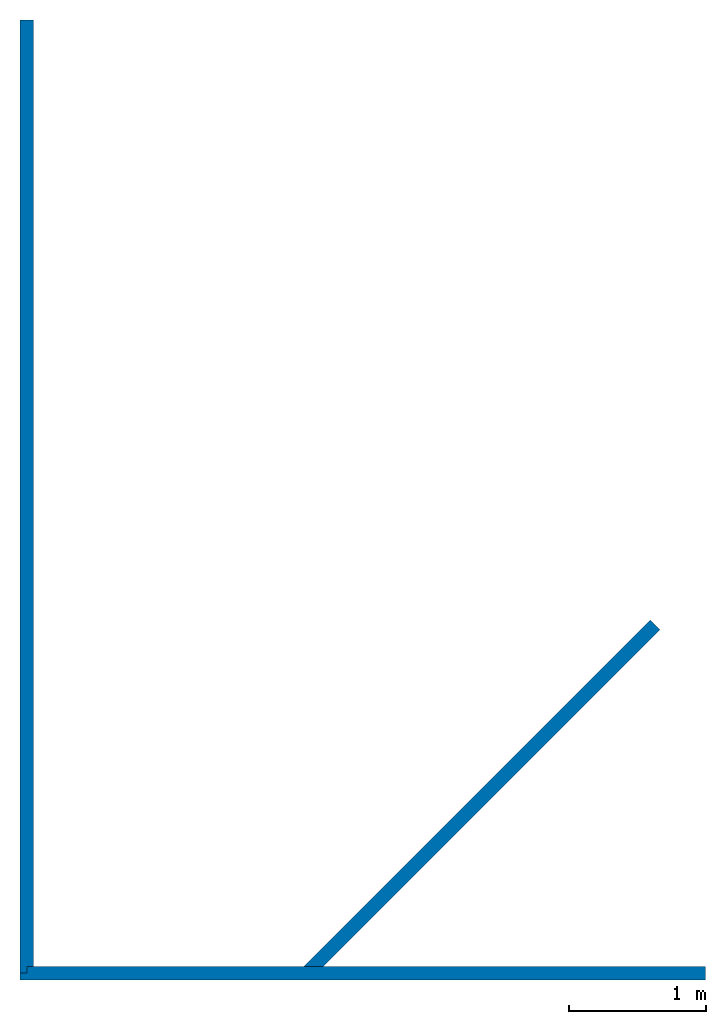
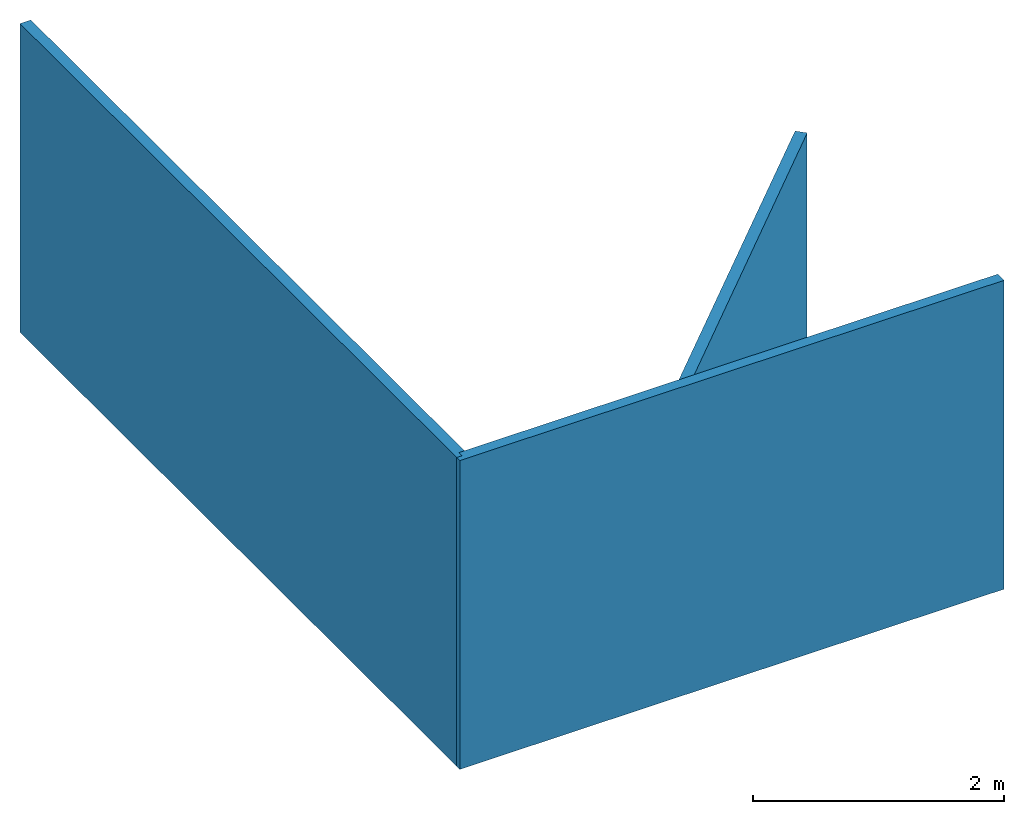
# One storey: 3 walls, 2 openings.
"""IFC4 building model written with IfcOpenShell, lengths in metres."""

from ifc_helpers import new_model, entity, si_unit, converted_unit, frame, origin_with_axes, origin_2d_with_axis, place, context, subcontext, project, spatial, line, indexed_curve, outline, extrude, material, layer, layer_set, layer_usage, type_object, element, save


model = new_model("IFC4")

# Units and contexts
model_context = context("Model", 3, precision=1e-05, world=origin_with_axes())
plan_context = context("Plan", 2, precision=1e-05, world=origin_2d_with_axis())
body_context = subcontext(model_context, "Body", "Model", "MODEL_VIEW")
ifc_project = project(units=[converted_unit("PLANEANGLEUNIT", "degree", entity("IfcReal", 0.0174532925199433), si_unit("PLANEANGLEUNIT", "RADIAN"), dimensions=[0, 0, 0, 0, 0, 0, 0]), si_unit("AREAUNIT", "SQUARE_METRE"), si_unit("VOLUMEUNIT", "CUBIC_METRE"), si_unit("LENGTHUNIT", "METRE")], contexts=[model_context, plan_context])

# Site, building, storey
site_placement = place(None, origin_with_axes())
site = spatial("IfcSite", under=ifc_project, at=site_placement)
building_placement = place(site_placement, origin_with_axes())
building = spatial("IfcBuilding", under=site, at=building_placement, Name="Building")
storey_placement = place(building_placement, origin_with_axes())
storey = spatial("IfcBuildingStorey", under=building, at=storey_placement, Name="Storey")

# Wall, opening
ifc_material = material()
ifc_layer = layer(ifc_material, 0.1)
ifc_layer_set = layer_set([ifc_layer])
ifc_layer_usage_1 = layer_usage(ifc_layer_set, "AXIS2", "POSITIVE", 0.0)
wall_type = type_object("IfcWallType", PredefinedType="SOLIDWALL", material=ifc_layer_set)
wall_1_placement = place(storey_placement, origin_with_axes())
wall_1 = element("IfcWall", 1, at=wall_1_placement, inside=storey, type_object=wall_type, material=ifc_layer_usage_1, Name="Wall", context=body_context, shape_type="SweptSolid", body=[
    extrude(outline(indexed_curve([(0.0, 0.0), (0.0, 0.1), (5.0, 0.1), (5.0, 0.0)], segments=[line(1, 2, 3, 4, 1)])), origin_with_axes(), (0.0, 0.0, 1.0), 3.0),
])
opening_1_placement = place(wall_1_placement, frame((0.0, 0.0500000007450581, 0.5), z_axis=(0.0, 0.0, 1.0), x_axis=(1.0, 0.0, 0.0)))
element("IfcOpeningElement", 2, at=opening_1_placement, cuts=wall_1, PredefinedType="OPENING", context=body_context, shape_type="SweptSolid", body=[
    extrude(outline(indexed_curve([(0.0, 0.5), (0.0500000007450581, 0.5), (0.0500000007450581, -2.5), (0.0, -2.5), (0.0, 0.5)])), frame((0.0, 0.0, 0.0), z_axis=(0.0, 1.0, 0.0), x_axis=(1.0, 0.0, 0.0)), (0.0, 0.0, 1.0), 0.0500000007450581),
])

ifc_layer_usage_2 = layer_usage(ifc_layer_set, "AXIS2", "POSITIVE", 0.0)
wall_2_placement = place(storey_placement, frame((5.28485315953731e-07, 7.0, 0.0), z_axis=(0.0, 0.0, 1.0), x_axis=(-4.37113882867379e-08, -1.0, 0.0)))
wall_2 = element("IfcWall", 3, at=wall_2_placement, inside=storey, type_object=wall_type, material=ifc_layer_usage_2, Name="Wall", context=body_context, shape_type="SweptSolid", body=[
    extrude(outline(indexed_curve([(0.0, 0.0), (0.0, 0.1), (6.94999980926514, 0.1), (6.94999980926514, 0.0)], segments=[line(1, 2, 3, 4, 1)])), origin_with_axes(), (0.0, 0.0, 1.0), 3.0),
])
opening_2_placement = place(wall_2_placement, frame((6.94999999816217, 0.0249997738187165, 0.0), z_axis=(0.0, 0.0, 1.0), x_axis=(-4.37113882867379e-08, 0.999999999999999, 0.0)))
element("IfcOpeningElement", 4, at=opening_2_placement, cuts=wall_2, PredefinedType="OPENING", context=body_context, shape_type="SweptSolid", body=[
    extrude(outline(indexed_curve([(0.449999988079071, 0.5), (0.5, 0.5), (0.5, -2.5), (0.449999988079071, -2.5), (0.449999988079071, 0.5)])), frame((0.025001123547554, 0.500000178813934, 0.5), z_axis=(1.0, -1.62920684942947e-07, -1.62920684942947e-07), x_axis=(-1.62920684942947e-07, -1.0, 7.16093850883226e-15)), (0.0, 0.0, 1.0), 0.0500000007450581),
])

# Wall
ifc_layer_usage_3 = layer_usage(ifc_layer_set, "AXIS2", "POSITIVE", 0.0)
wall_3_placement = place(storey_placement, frame((4.59626626968384, 2.62550616264343, 0.0), z_axis=(0.0, 0.0, 1.0), x_axis=(-0.707106828689575, -0.707106828689575, 0.0)))
element("IfcWall", 5, at=wall_3_placement, inside=storey, type_object=wall_type, material=ifc_layer_usage_3, Name="Wall", context=body_context, shape_type="SweptSolid", body=[
    extrude(outline(indexed_curve([(0.0, 0.0), (0.0, 0.1), (3.47160506706717, 0.1), (3.57160506706717, 0.0)], segments=[line(1, 2, 3, 4, 1)])), origin_with_axes(), (0.0, 0.0, 1.0), 3.0),
])

save(model, "model.ifc")
